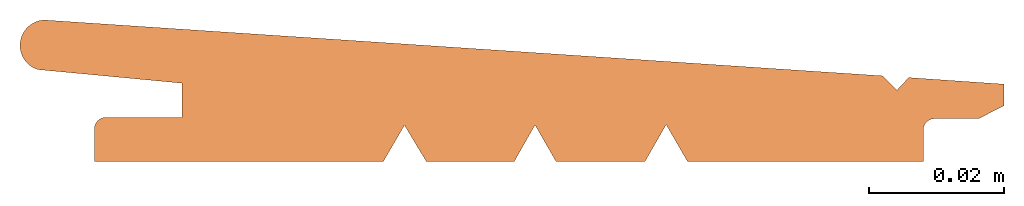
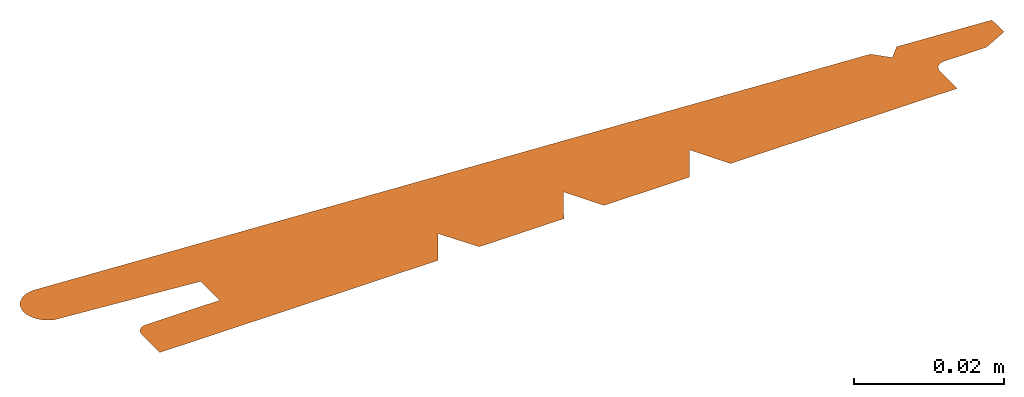
# One storey: 1 proxy.
"""IFC2X3 building model written with IfcOpenShell, lengths in millimetres."""

from ifc_helpers import new_model, entity, si_unit, converted_unit, direction, frame, origin, origin_with_axes, place, context, project, spatial, faceted_brep, element, save


model = new_model("IFC2X3")

# Units and contexts
model_context = context("Model", 3, precision=1e-05, world=origin(), true_north=direction((0.0, 1.0, 0.0)))
ifc_project = project(units=[si_unit("LENGTHUNIT", "METRE", prefix="MILLI"), si_unit("AREAUNIT", "SQUARE_METRE"), si_unit("VOLUMEUNIT", "CUBIC_METRE"), converted_unit("PLANEANGLEUNIT", "DEGREE", entity("IfcPlaneAngleMeasure", 0.01745), si_unit("PLANEANGLEUNIT", "RADIAN"), dimensions=[0, 0, 0, 0, 0, 0, 0]), si_unit("SOLIDANGLEUNIT", "STERADIAN"), si_unit("MASSUNIT", "GRAM"), si_unit("TIMEUNIT", "SECOND"), si_unit("THERMODYNAMICTEMPERATUREUNIT", "DEGREE_CELSIUS"), si_unit("LUMINOUSINTENSITYUNIT", "LUMEN")], contexts=[model_context])

# Site, building, storey
site_placement = place(None, origin_with_axes())
site = spatial("IfcSite", under=ifc_project, at=site_placement, CompositionType="ELEMENT")
building_placement = place(site_placement, origin_with_axes())
building = spatial("IfcBuilding", under=site, at=building_placement, Name="Default Building", CompositionType="ELEMENT")
storey_placement = place(building_placement, origin_with_axes())
storey = spatial("IfcBuildingStorey", under=building, at=storey_placement, Name="Default Building Storey", CompositionType="ELEMENT", Elevation=0.0)

# Proxy
proxy_placement = place(storey_placement, frame((-0.06923087490072755, 0.0, 0.0), z_axis=(0.0, 0.0, 1.0), x_axis=(1.0, 0.0, 0.0)))
element("IfcBuildingElementProxy", 1, at=proxy_placement, inside=storey, context=model_context, shape_type="Brep", body=[
    faceted_brep([(127.9725329162727, 12.71668787125542, 0.0), (3.596583507891351, 21.00067870910694, 0.0), (3.30549245295434, 20.97659631345279, 0.0), (3.01714259598413, 20.93003104710496, 0.0), (2.733267787290475, 20.86126290743312, 0.0), (2.455574968677187, 20.77070539788593, 0.0), (2.185733909585563, 20.65890304159104, 0.0), (1.925367166755557, 20.52652810713259, 0.0), (1.67604032777736, 20.3743765661942, 0.0), (1.439252597199006, 20.2033633073739, 0.0), (1.21642778179579, 20.01451663495071, 0.0), (1.008905729207205, 19.8089720856817, 0.0), (0.8179342714209015, 19.58796560080907, 0.0), (0.6446617215476174, 19.3528260943343, 0.0), (0.4901299690040049, 19.10496746224621, 0.0), (0.3552682146221056, 18.84588008075143, 0.0), (0.2408873833562985, 18.57712184462884, 0.0), (0.1476752481841918, 18.30030879959402, 0.0), (0.0761922945214536, 18.0171054250018, 0.0), (0.0268683500179121, 17.72921462531657, 0.0), (0.0, 17.4383674905325, 0.0), (-0.004251195899509896, 17.14631288711354, 0.0), (0.01414032479894436, 16.8548069420435, 0.0), (0.0550639737143126, 16.56560248321853, 0.0), (0.1182736765738532, 16.28043849967716, 0.0), (0.2033893528599803, 16.00102968504323, 0.0), (0.3098992012378701, 15.72905612705771, 0.0), (0.4371627770215329, 15.46615320519578, 0.0), (0.5844148431735308, 15.21390175711519, 0.0), (0.7507699716822355, 14.97381857306509, 0.0), (0.9352278676485071, 14.74734727541243, 0.0), (1.136679384068012, 14.5358496381276, 0.0), (1.353913191142239, 14.34059739842515, 0.0), (1.585623060015571, 14.16276460979636, 0.0), (1.830415717141284, 14.00342058241499, 0.0), (2.086819222048016, 13.86352345336537, 0.0), (2.353291818131217, 13.7439144253555, 0.0), (2.628231203249603, 13.64531270855753, 0.0), (24.0314210833866, 11.62304613017453, 0.0), (24.0314210833866, 6.534322130174528, 0.0), (12.80226508338659, 6.534322130174528, 0.0), (12.57652416809971, 6.533123307918525, 0.0), (12.35303433625682, 6.501300469072802, 0.0), (12.13593072164842, 6.439442417589372, 0.0), (11.92923029670406, 6.3486936857129, 0.0), (11.73675754822321, 6.230733357205417, 0.0), (11.5620737145827, 6.087744000000007, 0.0), (11.4084108937137, 5.922371283108906, 0.0), (11.2786122410192, 5.737675024976655, 0.0), (11.1750793637235, 5.537072579008928, 0.0), (11.09972788499302, 5.324275603789597, 0.0), (11.05395200000562, 5.103221387899055, 0.0), (11.03859867977221, 4.878000000000007, 0.0), (11.03859867977221, 0.0, 0.0), (53.90646267977227, 0.0, 0.0), (57.04484670958068, 5.386496913625725, 0.0), (60.28891665997293, 0.0, 0.0), (73.33268865997293, 0.0, 0.0), (76.41527317819919, 5.429844439170599, 0.0), (79.54131321280272, -0.02013296853963093, 0.0), (79.84969929543442, 0.0, 0.0), (92.73144833165695, 0.0, 0.0), (95.87520558959758, 5.473554666628407, 0.0), (99.04390231185762, 0.0, 0.0), (134.0361157917166, 0.0, 0.0), (134.0361157917166, 4.688728000000006, 0.0), (134.0500992748356, 4.904359708965674, 0.0), (134.0918154856891, 5.116379353016913, 0.0), (134.1605656325166, 5.321235373242813, 0.0), (134.2551980758192, 5.515496209198409, 0.0), (134.3741276195706, 5.695907781262616, 0.0), (134.5153620649687, 5.859447999999999, 0.0), (134.676535581926, 6.003377389435358, 0.0), (134.8549483392879, 6.125284976246503, 0.0), (135.0476117299324, 6.223128676181369, 0.0), (135.2512984331794, 6.295269501183296, 0.0), (135.4625964759111, 6.340499014217956, 0.0), (135.677966386821, 6.358059571903903, 0.0), (142.2205811173369, 6.358059571903903, 0.0), (146.0032300024114, 8.274893918824898, 0.0), (146.0032300024114, 11.48461791882491, 0.0), (132.8601377033898, 12.39115167661241, 0.0), (131.860390491026, 12.45773928287218, 0.0), (130.1054927844103, 10.57254248137613, 0.0)], [[[0, 1, 2, 3, 4, 5, 6, 7, 8, 9, 10, 11, 12, 13, 14, 15, 16, 17, 18, 19, 20, 21, 22, 23, 24, 25, 26, 27, 28, 29, 30, 31, 32, 33, 34, 35, 36, 37, 38, 39, 40, 41, 42, 43, 44, 45, 46, 47, 48, 49, 50, 51, 52, 53, 54, 55, 56, 57, 58, 59, 60, 61, 62, 63, 64, 65, 66, 67, 68, 69, 70, 71, 72, 73, 74, 75, 76, 77, 78, 79, 80, 81, 82, 83]]]),
])

save(model, "model.ifc")
